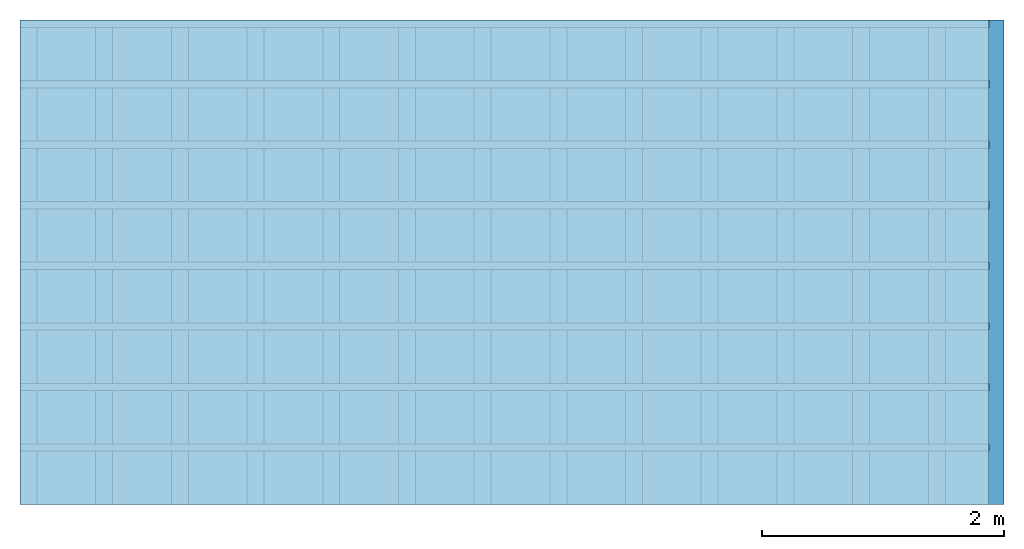
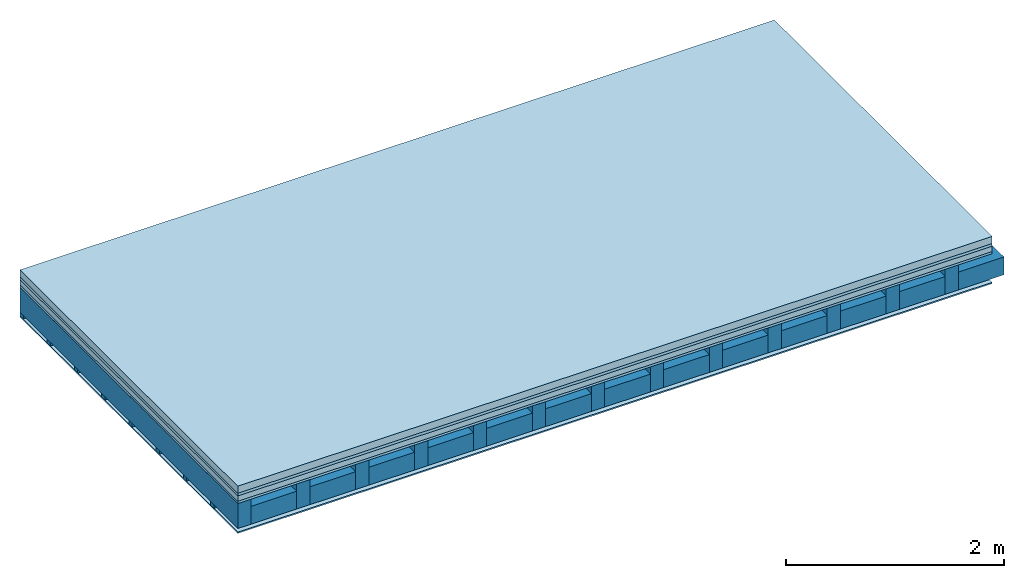
# One storey: 5 plates, 3 members, 1 element without a shape of its own.
"""IFC4 building model written with IfcOpenShell, lengths in metres."""

from ifc_helpers import new_model, si_unit, derived_unit, direction, frame, frame_2d, origin, origin_with_axes, place, context, project, spatial, rectangle, extrude, material, layer, layer_set, type_object, element, aggregate, save


model = new_model("IFC4")

# Units and contexts
plan_context = context("Plan", 3, precision=1e-05, world=origin(), true_north=direction((0.0, 1.0)))
model_context = context("Model", 3, precision=1e-05, world=origin(), true_north=direction((0.0, 1.0)))
ifc_project = project(units=[si_unit("LENGTHUNIT", "METRE"), derived_unit("SOUNDPRESSUREUNIT", [(si_unit("PRESSUREUNIT", "PASCAL", prefix="MICRO"), 0)]), si_unit("ENERGYUNIT", "JOULE", prefix="MEGA"), si_unit("MASSUNIT", "GRAM", prefix="KILO"), derived_unit("THERMALTRANSMITTANCEUNIT", [(si_unit("POWERUNIT", "WATT"), 1), (si_unit("AREAUNIT", "SQUARE_METRE"), -1), (si_unit("THERMODYNAMICTEMPERATUREUNIT", "KELVIN"), -1)]), derived_unit("AREADENSITYUNIT", [(si_unit("MASSUNIT", "GRAM", prefix="KILO"), 1), (si_unit("AREAUNIT", "SQUARE_METRE"), -1)]), derived_unit("USERDEFINED", [(si_unit("ENERGYUNIT", "JOULE", prefix="MEGA"), 1), (si_unit("AREAUNIT", "SQUARE_METRE"), -1)])], contexts=[plan_context, model_context])

# Site, building, storey
site = spatial("IfcSite", under=ifc_project)
building_placement = place(None, origin())
building = spatial("IfcBuilding", under=site, at=building_placement)
storey_placement = place(building_placement, origin())
storey = spatial("IfcBuildingStorey", under=building, at=storey_placement)

# Slab, members, plates
ifc_material_1 = material(Name="Cement screed", Category="04.006")
ifc_layer_1 = layer(ifc_material_1, 0.08, Name="On-material")
ifc_material_2 = material()
ifc_layer_2 = layer(ifc_material_2, 0.03, Name="Impact sound insulation")
ifc_material_3 = material(Name="Cement panels, glued on sub-floor", Category="02.007")
ifc_layer_3 = layer(ifc_material_3, 0.06, Name="on Supporting structure")
ifc_material_4 = material(Category="07.001")
ifc_layer_4 = layer(ifc_material_4, 0.025, Name="Sub-floor")
ifc_material_5 = material(Name="of the art")
ifc_layer_5 = layer(ifc_material_5, 0.0, Name="Bond")
ifc_layer_6 = layer(None, 0.28, Name="Supporting structure")
ifc_layer_7 = layer(ifc_material_5, 0.0, Name="Bond")
ifc_layer_8 = layer(None, 0.04, Name="Battens / profiles")
ifc_material_6 = material(Category="03.007")
ifc_layer_9 = layer(ifc_material_6, 0.015, Name="Ceiling covering 1st layer")
ifc_material_7 = material(Name="Glued joints")
ifc_layer_10 = layer(ifc_material_7, 0.0, Name="Surface / treatment")
ifc_layer_set = layer_set([ifc_layer_1, ifc_layer_2, ifc_layer_3, ifc_layer_4, ifc_layer_5, ifc_layer_6, ifc_layer_7, ifc_layer_8, ifc_layer_9, ifc_layer_10])
slab_type = type_object("IfcSlabType", Name="A0245", PredefinedType="NOTDEFINED", material=ifc_layer_set)
slab_placement = place(None, frame((0.0, 0.0, 0.0), z_axis=(0.0, 0.0, -1.0), x_axis=(1.0, 0.0, 0.0)))
slab = element("IfcSlab", 1, at=slab_placement, inside=storey, type_object=slab_type, material=ifc_layer_set, Name="Slab #1")
ifc_material_8 = material()
member_1_placement = place(slab_placement, origin())
member_1 = element("IfcMember", 2, at=member_1_placement, material=ifc_material_8, Name="Supporting structure", context=plan_context, shape_type="SweptSolid", body=[
    extrude(rectangle(XDim=0.14, YDim=0.28, at=frame_2d((0.07, 0.14), x_axis=(1.0, 0.0))), frame((0.0, 4.0, 0.195), z_axis=(0.0, -1.0, 0.0), x_axis=(1.0, 0.0, 0.0)), (0.0, 0.0, 1.0), 4.0),
    extrude(rectangle(XDim=0.14, YDim=0.28, at=frame_2d((0.07, 0.14), x_axis=(1.0, 0.0))), frame((0.625, 4.0, 0.195), z_axis=(0.0, -1.0, 0.0), x_axis=(1.0, 0.0, 0.0)), (0.0, 0.0, 1.0), 4.0),
    extrude(rectangle(XDim=0.14, YDim=0.28, at=frame_2d((0.07, 0.14), x_axis=(1.0, 0.0))), frame((1.25, 4.0, 0.195), z_axis=(0.0, -1.0, 0.0), x_axis=(1.0, 0.0, 0.0)), (0.0, 0.0, 1.0), 4.0),
    extrude(rectangle(XDim=0.14, YDim=0.28, at=frame_2d((0.07, 0.14), x_axis=(1.0, 0.0))), frame((1.875, 4.0, 0.195), z_axis=(0.0, -1.0, 0.0), x_axis=(1.0, 0.0, 0.0)), (0.0, 0.0, 1.0), 4.0),
    extrude(rectangle(XDim=0.14, YDim=0.28, at=frame_2d((0.07, 0.14), x_axis=(1.0, 0.0))), frame((2.5, 4.0, 0.195), z_axis=(0.0, -1.0, 0.0), x_axis=(1.0, 0.0, 0.0)), (0.0, 0.0, 1.0), 4.0),
    extrude(rectangle(XDim=0.14, YDim=0.28, at=frame_2d((0.07, 0.14), x_axis=(1.0, 0.0))), frame((3.125, 4.0, 0.195), z_axis=(0.0, -1.0, 0.0), x_axis=(1.0, 0.0, 0.0)), (0.0, 0.0, 1.0), 4.0),
    extrude(rectangle(XDim=0.14, YDim=0.28, at=frame_2d((0.07, 0.14), x_axis=(1.0, 0.0))), frame((3.75, 4.0, 0.195), z_axis=(0.0, -1.0, 0.0), x_axis=(1.0, 0.0, 0.0)), (0.0, 0.0, 1.0), 4.0),
    extrude(rectangle(XDim=0.14, YDim=0.28, at=frame_2d((0.07, 0.14), x_axis=(1.0, 0.0))), frame((4.375, 4.0, 0.195), z_axis=(0.0, -1.0, 0.0), x_axis=(1.0, 0.0, 0.0)), (0.0, 0.0, 1.0), 4.0),
    extrude(rectangle(XDim=0.14, YDim=0.28, at=frame_2d((0.07, 0.14), x_axis=(1.0, 0.0))), frame((5.0, 4.0, 0.195), z_axis=(0.0, -1.0, 0.0), x_axis=(1.0, 0.0, 0.0)), (0.0, 0.0, 1.0), 4.0),
    extrude(rectangle(XDim=0.14, YDim=0.28, at=frame_2d((0.07, 0.14), x_axis=(1.0, 0.0))), frame((5.625, 4.0, 0.195), z_axis=(0.0, -1.0, 0.0), x_axis=(1.0, 0.0, 0.0)), (0.0, 0.0, 1.0), 4.0),
    extrude(rectangle(XDim=0.14, YDim=0.28, at=frame_2d((0.07, 0.14), x_axis=(1.0, 0.0))), frame((6.25, 4.0, 0.195), z_axis=(0.0, -1.0, 0.0), x_axis=(1.0, 0.0, 0.0)), (0.0, 0.0, 1.0), 4.0),
    extrude(rectangle(XDim=0.14, YDim=0.28, at=frame_2d((0.07, 0.14), x_axis=(1.0, 0.0))), frame((6.875, 4.0, 0.195), z_axis=(0.0, -1.0, 0.0), x_axis=(1.0, 0.0, 0.0)), (0.0, 0.0, 1.0), 4.0),
    extrude(rectangle(XDim=0.14, YDim=0.28, at=frame_2d((0.07, 0.14), x_axis=(1.0, 0.0))), frame((7.5, 4.0, 0.195), z_axis=(0.0, -1.0, 0.0), x_axis=(1.0, 0.0, 0.0)), (0.0, 0.0, 1.0), 4.0),
])
ifc_material_9 = material()
member_2_placement = place(slab_placement, origin())
member_2 = element("IfcMember", 3, at=member_2_placement, material=ifc_material_9, Name="Cavity", context=plan_context, shape_type="SweptSolid", body=[
    extrude(rectangle(XDim=0.485, YDim=0.2, at=frame_2d((0.2425, 0.1), x_axis=(1.0, 0.0))), frame((0.14, 4.0, 0.275), z_axis=(0.0, -1.0, 0.0), x_axis=(1.0, 0.0, 0.0)), (0.0, 0.0, 1.0), 4.0),
    extrude(rectangle(XDim=0.485, YDim=0.2, at=frame_2d((0.2425, 0.1), x_axis=(1.0, 0.0))), frame((0.765, 4.0, 0.275), z_axis=(0.0, -1.0, 0.0), x_axis=(1.0, 0.0, 0.0)), (0.0, 0.0, 1.0), 4.0),
    extrude(rectangle(XDim=0.485, YDim=0.2, at=frame_2d((0.2425, 0.1), x_axis=(1.0, 0.0))), frame((1.39, 4.0, 0.275), z_axis=(0.0, -1.0, 0.0), x_axis=(1.0, 0.0, 0.0)), (0.0, 0.0, 1.0), 4.0),
    extrude(rectangle(XDim=0.485, YDim=0.2, at=frame_2d((0.2425, 0.1), x_axis=(1.0, 0.0))), frame((2.015, 4.0, 0.275), z_axis=(0.0, -1.0, 0.0), x_axis=(1.0, 0.0, 0.0)), (0.0, 0.0, 1.0), 4.0),
    extrude(rectangle(XDim=0.485, YDim=0.2, at=frame_2d((0.2425, 0.1), x_axis=(1.0, 0.0))), frame((2.64, 4.0, 0.275), z_axis=(0.0, -1.0, 0.0), x_axis=(1.0, 0.0, 0.0)), (0.0, 0.0, 1.0), 4.0),
    extrude(rectangle(XDim=0.485, YDim=0.2, at=frame_2d((0.2425, 0.1), x_axis=(1.0, 0.0))), frame((3.265, 4.0, 0.275), z_axis=(0.0, -1.0, 0.0), x_axis=(1.0, 0.0, 0.0)), (0.0, 0.0, 1.0), 4.0),
    extrude(rectangle(XDim=0.485, YDim=0.2, at=frame_2d((0.2425, 0.1), x_axis=(1.0, 0.0))), frame((3.89, 4.0, 0.275), z_axis=(0.0, -1.0, 0.0), x_axis=(1.0, 0.0, 0.0)), (0.0, 0.0, 1.0), 4.0),
    extrude(rectangle(XDim=0.485, YDim=0.2, at=frame_2d((0.2425, 0.1), x_axis=(1.0, 0.0))), frame((4.515, 4.0, 0.275), z_axis=(0.0, -1.0, 0.0), x_axis=(1.0, 0.0, 0.0)), (0.0, 0.0, 1.0), 4.0),
    extrude(rectangle(XDim=0.485, YDim=0.2, at=frame_2d((0.2425, 0.1), x_axis=(1.0, 0.0))), frame((5.14, 4.0, 0.275), z_axis=(0.0, -1.0, 0.0), x_axis=(1.0, 0.0, 0.0)), (0.0, 0.0, 1.0), 4.0),
    extrude(rectangle(XDim=0.485, YDim=0.2, at=frame_2d((0.2425, 0.1), x_axis=(1.0, 0.0))), frame((5.765, 4.0, 0.275), z_axis=(0.0, -1.0, 0.0), x_axis=(1.0, 0.0, 0.0)), (0.0, 0.0, 1.0), 4.0),
    extrude(rectangle(XDim=0.485, YDim=0.2, at=frame_2d((0.2425, 0.1), x_axis=(1.0, 0.0))), frame((6.39, 4.0, 0.275), z_axis=(0.0, -1.0, 0.0), x_axis=(1.0, 0.0, 0.0)), (0.0, 0.0, 1.0), 4.0),
    extrude(rectangle(XDim=0.485, YDim=0.2, at=frame_2d((0.2425, 0.1), x_axis=(1.0, 0.0))), frame((7.015, 4.0, 0.275), z_axis=(0.0, -1.0, 0.0), x_axis=(1.0, 0.0, 0.0)), (0.0, 0.0, 1.0), 4.0),
    extrude(rectangle(XDim=0.485, YDim=0.2, at=frame_2d((0.2425, 0.1), x_axis=(1.0, 0.0))), frame((7.64, 4.0, 0.275), z_axis=(0.0, -1.0, 0.0), x_axis=(1.0, 0.0, 0.0)), (0.0, 0.0, 1.0), 4.0),
])
ifc_material_10 = material()
member_3_placement = place(slab_placement, origin())
member_3 = element("IfcMember", 4, at=member_3_placement, material=ifc_material_10, Name="Battens / profiles", context=plan_context, shape_type="SweptSolid", body=[
    extrude(rectangle(XDim=0.06, YDim=0.04, at=frame_2d((0.03, 0.02), x_axis=(1.0, 0.0))), frame((0.0, 0.0, 0.475), z_axis=(1.0, 0.0, 0.0), x_axis=(0.0, 1.0, 0.0)), (0.0, 0.0, 1.0), 8.0),
    extrude(rectangle(XDim=0.06, YDim=0.04, at=frame_2d((0.03, 0.02), x_axis=(1.0, 0.0))), frame((0.0, 0.5, 0.475), z_axis=(1.0, 0.0, 0.0), x_axis=(0.0, 1.0, 0.0)), (0.0, 0.0, 1.0), 8.0),
    extrude(rectangle(XDim=0.06, YDim=0.04, at=frame_2d((0.03, 0.02), x_axis=(1.0, 0.0))), frame((0.0, 1.0, 0.475), z_axis=(1.0, 0.0, 0.0), x_axis=(0.0, 1.0, 0.0)), (0.0, 0.0, 1.0), 8.0),
    extrude(rectangle(XDim=0.06, YDim=0.04, at=frame_2d((0.03, 0.02), x_axis=(1.0, 0.0))), frame((0.0, 1.5, 0.475), z_axis=(1.0, 0.0, 0.0), x_axis=(0.0, 1.0, 0.0)), (0.0, 0.0, 1.0), 8.0),
    extrude(rectangle(XDim=0.06, YDim=0.04, at=frame_2d((0.03, 0.02), x_axis=(1.0, 0.0))), frame((0.0, 2.0, 0.475), z_axis=(1.0, 0.0, 0.0), x_axis=(0.0, 1.0, 0.0)), (0.0, 0.0, 1.0), 8.0),
    extrude(rectangle(XDim=0.06, YDim=0.04, at=frame_2d((0.03, 0.02), x_axis=(1.0, 0.0))), frame((0.0, 2.5, 0.475), z_axis=(1.0, 0.0, 0.0), x_axis=(0.0, 1.0, 0.0)), (0.0, 0.0, 1.0), 8.0),
    extrude(rectangle(XDim=0.06, YDim=0.04, at=frame_2d((0.03, 0.02), x_axis=(1.0, 0.0))), frame((0.0, 3.0, 0.475), z_axis=(1.0, 0.0, 0.0), x_axis=(0.0, 1.0, 0.0)), (0.0, 0.0, 1.0), 8.0),
    extrude(rectangle(XDim=0.06, YDim=0.04, at=frame_2d((0.03, 0.02), x_axis=(1.0, 0.0))), frame((0.0, 3.5, 0.475), z_axis=(1.0, 0.0, 0.0), x_axis=(0.0, 1.0, 0.0)), (0.0, 0.0, 1.0), 8.0),
])
plate_1_placement = place(slab_placement, origin())
plate_1 = element("IfcPlate", 5, at=plate_1_placement, material=ifc_material_1, Name="On-material", context=plan_context, shape_type="SweptSolid", body=[
    extrude(rectangle(XDim=8.0, YDim=4.0, at=frame_2d((4.0, 2.0), x_axis=(1.0, 0.0))), origin_with_axes(), (0.0, 0.0, 1.0), 0.08),
])
plate_2_placement = place(slab_placement, origin())
plate_2 = element("IfcPlate", 6, at=plate_2_placement, material=ifc_material_2, Name="Impact sound insulation", context=plan_context, shape_type="SweptSolid", body=[
    extrude(rectangle(XDim=8.0, YDim=4.0, at=frame_2d((4.0, 2.0), x_axis=(1.0, 0.0))), frame((0.0, 0.0, 0.08), z_axis=(0.0, 0.0, 1.0), x_axis=(1.0, 0.0, 0.0)), (0.0, 0.0, 1.0), 0.03),
])
plate_3_placement = place(slab_placement, origin())
plate_3 = element("IfcPlate", 7, at=plate_3_placement, material=ifc_material_3, Name="on Supporting structure", context=plan_context, shape_type="SweptSolid", body=[
    extrude(rectangle(XDim=8.0, YDim=4.0, at=frame_2d((4.0, 2.0), x_axis=(1.0, 0.0))), frame((0.0, 0.0, 0.11), z_axis=(0.0, 0.0, 1.0), x_axis=(1.0, 0.0, 0.0)), (0.0, 0.0, 1.0), 0.06),
])
plate_4_placement = place(slab_placement, origin())
plate_4 = element("IfcPlate", 8, at=plate_4_placement, material=ifc_material_4, Name="Sub-floor", context=plan_context, shape_type="SweptSolid", body=[
    extrude(rectangle(XDim=8.0, YDim=4.0, at=frame_2d((4.0, 2.0), x_axis=(1.0, 0.0))), frame((0.0, 0.0, 0.17), z_axis=(0.0, 0.0, 1.0), x_axis=(1.0, 0.0, 0.0)), (0.0, 0.0, 1.0), 0.025),
])
plate_5_placement = place(slab_placement, origin())
plate_5 = element("IfcPlate", 9, at=plate_5_placement, material=ifc_material_6, Name="Ceiling covering 1st layer", context=plan_context, shape_type="SweptSolid", body=[
    extrude(rectangle(XDim=8.0, YDim=4.0, at=frame_2d((4.0, 2.0), x_axis=(1.0, 0.0))), frame((0.0, 0.0, 0.515), z_axis=(0.0, 0.0, 1.0), x_axis=(1.0, 0.0, 0.0)), (0.0, 0.0, 1.0), 0.015),
])
aggregate(slab, [plate_1, plate_2, plate_3, plate_4, member_1, member_2, member_3, plate_5])

save(model, "model.ifc")
